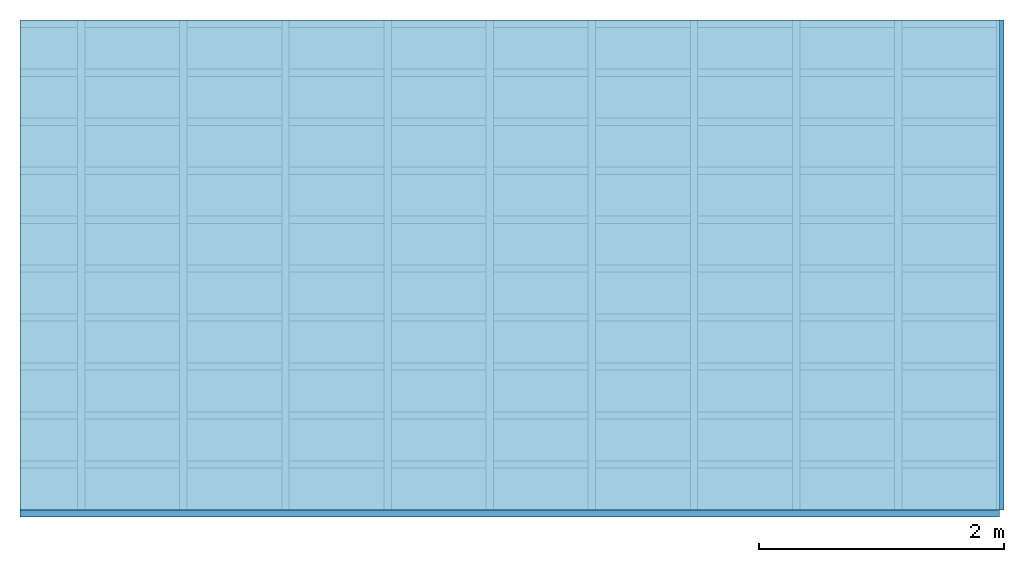
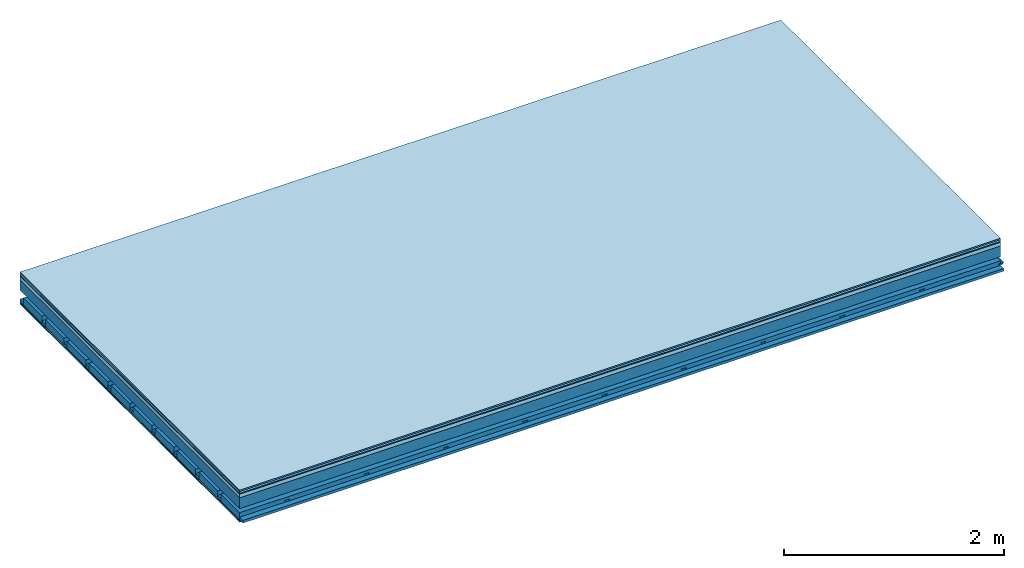
# One storey: 7 plates, 4 members, 1 element without a shape of its own.
"""IFC4 building model written with IfcOpenShell, lengths in metres."""

from ifc_helpers import new_model, si_unit, derived_unit, direction, frame, frame_2d, origin, origin_with_axes, place, context, project, spatial, polyline, rectangle, outline, extrude, material, layer, layer_set, type_object, element, aggregate, save


model = new_model("IFC4")

# Units and contexts
plan_context = context("Plan", 3, precision=1e-05, world=origin(), true_north=direction((0.0, 1.0)))
model_context = context("Model", 3, precision=1e-05, world=origin(), true_north=direction((0.0, 1.0)))
ifc_project = project(units=[si_unit("LENGTHUNIT", "METRE"), derived_unit("SOUNDPRESSUREUNIT", [(si_unit("PRESSUREUNIT", "PASCAL", prefix="MICRO"), 0)]), si_unit("ENERGYUNIT", "JOULE", prefix="MEGA"), si_unit("MASSUNIT", "GRAM", prefix="KILO"), derived_unit("THERMALTRANSMITTANCEUNIT", [(si_unit("POWERUNIT", "WATT"), 1), (si_unit("AREAUNIT", "SQUARE_METRE"), -1), (si_unit("THERMODYNAMICTEMPERATUREUNIT", "KELVIN"), -1)]), derived_unit("AREADENSITYUNIT", [(si_unit("MASSUNIT", "GRAM", prefix="KILO"), 1), (si_unit("AREAUNIT", "SQUARE_METRE"), -1)]), derived_unit("USERDEFINED", [(si_unit("ENERGYUNIT", "JOULE", prefix="MEGA"), 1), (si_unit("AREAUNIT", "SQUARE_METRE"), -1)])], contexts=[plan_context, model_context])

# Site, building, storey
site = spatial("IfcSite", under=ifc_project)
building_placement = place(None, origin())
building = spatial("IfcBuilding", under=site, at=building_placement)
storey_placement = place(building_placement, origin())
storey = spatial("IfcBuildingStorey", under=building, at=storey_placement)

# Slab, members, plates
ifc_material_1 = material(Category="11.013")
ifc_layer_1 = layer(ifc_material_1, 0.015, Name="Flooring")
ifc_material_2 = material(Category="03.007")
ifc_layer_2 = layer(ifc_material_2, 0.02, Name="On-material")
ifc_material_3 = material(Name="Wood fiber generic product", Category="10.009")
ifc_layer_3 = layer(ifc_material_3, 0.01, Name="Impact sound insulation")
ifc_material_4 = material(Name="Concrete panels", Category="02.007")
ifc_layer_4 = layer(ifc_material_4, 0.04, Name="on Supporting structure")
ifc_material_5 = material(Name="no composite action")
ifc_layer_5 = layer(ifc_material_5, 0.0, Name="Bond")
ifc_layer_6 = layer(None, 0.12, Name="Supporting structure")
ifc_layer_7 = layer(ifc_material_5, 0.0, Name="Bond")
ifc_layer_8 = layer(None, 0.095, Name="Coupling")
ifc_layer_9 = layer(None, 0.03, Name="Battens / profiles")
ifc_material_6 = material(Name="Plasterboard type A", Category="03.008")
ifc_layer_10 = layer(ifc_material_6, 0.0125, Name="Ceiling covering 1st layer")
ifc_layer_11 = layer(ifc_material_6, 0.0125, Name="Ceiling covering layer 2")
ifc_material_7 = material(Category="04.001")
ifc_layer_12 = layer(ifc_material_7, 0.003, Name="Surface / treatment")
ifc_layer_set = layer_set([ifc_layer_1, ifc_layer_2, ifc_layer_3, ifc_layer_4, ifc_layer_5, ifc_layer_6, ifc_layer_7, ifc_layer_8, ifc_layer_9, ifc_layer_10, ifc_layer_11, ifc_layer_12])
slab_type = type_object("IfcSlabType", Name="A2132", PredefinedType="NOTDEFINED", material=ifc_layer_set)
slab_placement = place(None, frame((0.0, 0.0, 0.0), z_axis=(0.0, 0.0, -1.0), x_axis=(1.0, 0.0, 0.0)))
slab = element("IfcSlab", 1, at=slab_placement, inside=storey, type_object=slab_type, material=ifc_layer_set, Name="Slab #1")
ifc_material_8 = material(Name="Solid timber panel")
member_1_placement = place(slab_placement, origin())
member_1 = element("IfcMember", 2, at=member_1_placement, material=ifc_material_8, Name="Supporting structure", context=plan_context, shape_type="SweptSolid", body=[
    extrude(rectangle(XDim=1.0, YDim=0.12, at=frame_2d((0.5, 0.06), x_axis=(1.0, 0.0))), frame((0.0, 4.0, 0.085), z_axis=(0.0, -1.0, 0.0), x_axis=(1.0, 0.0, 0.0)), (0.0, 0.0, 1.0), 4.0),
    extrude(rectangle(XDim=1.0, YDim=0.12, at=frame_2d((0.5, 0.06), x_axis=(1.0, 0.0))), frame((1.0, 4.0, 0.085), z_axis=(0.0, -1.0, 0.0), x_axis=(1.0, 0.0, 0.0)), (0.0, 0.0, 1.0), 4.0),
    extrude(rectangle(XDim=1.0, YDim=0.12, at=frame_2d((0.5, 0.06), x_axis=(1.0, 0.0))), frame((2.0, 4.0, 0.085), z_axis=(0.0, -1.0, 0.0), x_axis=(1.0, 0.0, 0.0)), (0.0, 0.0, 1.0), 4.0),
    extrude(rectangle(XDim=1.0, YDim=0.12, at=frame_2d((0.5, 0.06), x_axis=(1.0, 0.0))), frame((3.0, 4.0, 0.085), z_axis=(0.0, -1.0, 0.0), x_axis=(1.0, 0.0, 0.0)), (0.0, 0.0, 1.0), 4.0),
    extrude(rectangle(XDim=1.0, YDim=0.12, at=frame_2d((0.5, 0.06), x_axis=(1.0, 0.0))), frame((4.0, 4.0, 0.085), z_axis=(0.0, -1.0, 0.0), x_axis=(1.0, 0.0, 0.0)), (0.0, 0.0, 1.0), 4.0),
    extrude(rectangle(XDim=1.0, YDim=0.12, at=frame_2d((0.5, 0.06), x_axis=(1.0, 0.0))), frame((5.0, 4.0, 0.085), z_axis=(0.0, -1.0, 0.0), x_axis=(1.0, 0.0, 0.0)), (0.0, 0.0, 1.0), 4.0),
    extrude(rectangle(XDim=1.0, YDim=0.12, at=frame_2d((0.5, 0.06), x_axis=(1.0, 0.0))), frame((6.0, 4.0, 0.085), z_axis=(0.0, -1.0, 0.0), x_axis=(1.0, 0.0, 0.0)), (0.0, 0.0, 1.0), 4.0),
    extrude(rectangle(XDim=1.0, YDim=0.12, at=frame_2d((0.5, 0.06), x_axis=(1.0, 0.0))), frame((7.0, 4.0, 0.085), z_axis=(0.0, -1.0, 0.0), x_axis=(1.0, 0.0, 0.0)), (0.0, 0.0, 1.0), 4.0),
])
ifc_material_9 = material()
member_2_placement = place(slab_placement, origin())
member_2 = element("IfcMember", 3, at=member_2_placement, material=ifc_material_9, Name="Coupling", context=plan_context, shape_type="SweptSolid", body=[
    extrude(outline(polyline([(0.0, 0.0), (0.06, 0.0), (0.04, 0.02), (0.02, 0.02), (0.0, 0.0)])), frame((0.47, 4.0, 0.28), z_axis=(0.0, -1.0, 0.0), x_axis=(1.0, 0.0, 0.0)), (0.0, 0.0, 1.0), 4.0),
    extrude(outline(polyline([(0.0, 0.0), (0.06, 0.0), (0.04, 0.02), (0.02, 0.02), (0.0, 0.0)])), frame((1.304, 4.0, 0.28), z_axis=(0.0, -1.0, 0.0), x_axis=(1.0, 0.0, 0.0)), (0.0, 0.0, 1.0), 4.0),
    extrude(outline(polyline([(0.0, 0.0), (0.06, 0.0), (0.04, 0.02), (0.02, 0.02), (0.0, 0.0)])), frame((2.138, 4.0, 0.28), z_axis=(0.0, -1.0, 0.0), x_axis=(1.0, 0.0, 0.0)), (0.0, 0.0, 1.0), 4.0),
    extrude(outline(polyline([(0.0, 0.0), (0.06, 0.0), (0.04, 0.02), (0.02, 0.02), (0.0, 0.0)])), frame((2.972, 4.0, 0.28), z_axis=(0.0, -1.0, 0.0), x_axis=(1.0, 0.0, 0.0)), (0.0, 0.0, 1.0), 4.0),
    extrude(outline(polyline([(0.0, 0.0), (0.06, 0.0), (0.04, 0.02), (0.02, 0.02), (0.0, 0.0)])), frame((3.806, 4.0, 0.28), z_axis=(0.0, -1.0, 0.0), x_axis=(1.0, 0.0, 0.0)), (0.0, 0.0, 1.0), 4.0),
    extrude(outline(polyline([(0.0, 0.0), (0.06, 0.0), (0.04, 0.02), (0.02, 0.02), (0.0, 0.0)])), frame((4.64, 4.0, 0.28), z_axis=(0.0, -1.0, 0.0), x_axis=(1.0, 0.0, 0.0)), (0.0, 0.0, 1.0), 4.0),
    extrude(outline(polyline([(0.0, 0.0), (0.06, 0.0), (0.04, 0.02), (0.02, 0.02), (0.0, 0.0)])), frame((5.474, 4.0, 0.28), z_axis=(0.0, -1.0, 0.0), x_axis=(1.0, 0.0, 0.0)), (0.0, 0.0, 1.0), 4.0),
    extrude(outline(polyline([(0.0, 0.0), (0.06, 0.0), (0.04, 0.02), (0.02, 0.02), (0.0, 0.0)])), frame((6.308, 4.0, 0.28), z_axis=(0.0, -1.0, 0.0), x_axis=(1.0, 0.0, 0.0)), (0.0, 0.0, 1.0), 4.0),
    extrude(outline(polyline([(0.0, 0.0), (0.06, 0.0), (0.04, 0.02), (0.02, 0.02), (0.0, 0.0)])), frame((7.142, 4.0, 0.28), z_axis=(0.0, -1.0, 0.0), x_axis=(1.0, 0.0, 0.0)), (0.0, 0.0, 1.0), 4.0),
    extrude(outline(polyline([(0.0, 0.0), (0.06, 0.0), (0.04, 0.02), (0.02, 0.02), (0.0, 0.0)])), frame((7.976, 4.0, 0.28), z_axis=(0.0, -1.0, 0.0), x_axis=(1.0, 0.0, 0.0)), (0.0, 0.0, 1.0), 4.0),
])
member_3_placement = place(slab_placement, origin())
member_3 = element("IfcMember", 4, at=member_3_placement, material=ifc_material_9, Name="Battens / profiles", context=plan_context, shape_type="SweptSolid", body=[
    extrude(rectangle(XDim=0.06, YDim=0.03, at=frame_2d((0.03, 0.015), x_axis=(1.0, 0.0))), frame((0.0, 0.0, 0.3), z_axis=(1.0, 0.0, 0.0), x_axis=(0.0, 1.0, 0.0)), (0.0, 0.0, 1.0), 8.0),
    extrude(rectangle(XDim=0.06, YDim=0.03, at=frame_2d((0.03, 0.015), x_axis=(1.0, 0.0))), frame((0.0, 0.4, 0.3), z_axis=(1.0, 0.0, 0.0), x_axis=(0.0, 1.0, 0.0)), (0.0, 0.0, 1.0), 8.0),
    extrude(rectangle(XDim=0.06, YDim=0.03, at=frame_2d((0.03, 0.015), x_axis=(1.0, 0.0))), frame((0.0, 0.8, 0.3), z_axis=(1.0, 0.0, 0.0), x_axis=(0.0, 1.0, 0.0)), (0.0, 0.0, 1.0), 8.0),
    extrude(rectangle(XDim=0.06, YDim=0.03, at=frame_2d((0.03, 0.015), x_axis=(1.0, 0.0))), frame((0.0, 1.2, 0.3), z_axis=(1.0, 0.0, 0.0), x_axis=(0.0, 1.0, 0.0)), (0.0, 0.0, 1.0), 8.0),
    extrude(rectangle(XDim=0.06, YDim=0.03, at=frame_2d((0.03, 0.015), x_axis=(1.0, 0.0))), frame((0.0, 1.6, 0.3), z_axis=(1.0, 0.0, 0.0), x_axis=(0.0, 1.0, 0.0)), (0.0, 0.0, 1.0), 8.0),
    extrude(rectangle(XDim=0.06, YDim=0.03, at=frame_2d((0.03, 0.015), x_axis=(1.0, 0.0))), frame((0.0, 2.0, 0.3), z_axis=(1.0, 0.0, 0.0), x_axis=(0.0, 1.0, 0.0)), (0.0, 0.0, 1.0), 8.0),
    extrude(rectangle(XDim=0.06, YDim=0.03, at=frame_2d((0.03, 0.015), x_axis=(1.0, 0.0))), frame((0.0, 2.4, 0.3), z_axis=(1.0, 0.0, 0.0), x_axis=(0.0, 1.0, 0.0)), (0.0, 0.0, 1.0), 8.0),
    extrude(rectangle(XDim=0.06, YDim=0.03, at=frame_2d((0.03, 0.015), x_axis=(1.0, 0.0))), frame((0.0, 2.8, 0.3), z_axis=(1.0, 0.0, 0.0), x_axis=(0.0, 1.0, 0.0)), (0.0, 0.0, 1.0), 8.0),
    extrude(rectangle(XDim=0.06, YDim=0.03, at=frame_2d((0.03, 0.015), x_axis=(1.0, 0.0))), frame((0.0, 3.2, 0.3), z_axis=(1.0, 0.0, 0.0), x_axis=(0.0, 1.0, 0.0)), (0.0, 0.0, 1.0), 8.0),
    extrude(rectangle(XDim=0.06, YDim=0.03, at=frame_2d((0.03, 0.015), x_axis=(1.0, 0.0))), frame((0.0, 3.6, 0.3), z_axis=(1.0, 0.0, 0.0), x_axis=(0.0, 1.0, 0.0)), (0.0, 0.0, 1.0), 8.0),
    extrude(rectangle(XDim=0.06, YDim=0.03, at=frame_2d((0.03, 0.015), x_axis=(1.0, 0.0))), frame((0.0, 4.0, 0.3), z_axis=(1.0, 0.0, 0.0), x_axis=(0.0, 1.0, 0.0)), (0.0, 0.0, 1.0), 8.0),
])
ifc_material_10 = material()
member_4_placement = place(slab_placement, origin())
member_4 = element("IfcMember", 5, at=member_4_placement, material=ifc_material_10, Name="Cavity", context=plan_context, shape_type="SweptSolid", body=[
    extrude(rectangle(XDim=0.34, YDim=0.08, at=frame_2d((0.17, 0.04), x_axis=(1.0, 0.0))), frame((0.0, 0.06, 0.25), z_axis=(1.0, 0.0, 0.0), x_axis=(0.0, 1.0, 0.0)), (0.0, 0.0, 1.0), 8.0),
    extrude(rectangle(XDim=0.34, YDim=0.08, at=frame_2d((0.17, 0.04), x_axis=(1.0, 0.0))), frame((0.0, 0.46, 0.25), z_axis=(1.0, 0.0, 0.0), x_axis=(0.0, 1.0, 0.0)), (0.0, 0.0, 1.0), 8.0),
    extrude(rectangle(XDim=0.34, YDim=0.08, at=frame_2d((0.17, 0.04), x_axis=(1.0, 0.0))), frame((0.0, 0.86, 0.25), z_axis=(1.0, 0.0, 0.0), x_axis=(0.0, 1.0, 0.0)), (0.0, 0.0, 1.0), 8.0),
    extrude(rectangle(XDim=0.34, YDim=0.08, at=frame_2d((0.17, 0.04), x_axis=(1.0, 0.0))), frame((0.0, 1.26, 0.25), z_axis=(1.0, 0.0, 0.0), x_axis=(0.0, 1.0, 0.0)), (0.0, 0.0, 1.0), 8.0),
    extrude(rectangle(XDim=0.34, YDim=0.08, at=frame_2d((0.17, 0.04), x_axis=(1.0, 0.0))), frame((0.0, 1.66, 0.25), z_axis=(1.0, 0.0, 0.0), x_axis=(0.0, 1.0, 0.0)), (0.0, 0.0, 1.0), 8.0),
    extrude(rectangle(XDim=0.34, YDim=0.08, at=frame_2d((0.17, 0.04), x_axis=(1.0, 0.0))), frame((0.0, 2.06, 0.25), z_axis=(1.0, 0.0, 0.0), x_axis=(0.0, 1.0, 0.0)), (0.0, 0.0, 1.0), 8.0),
    extrude(rectangle(XDim=0.34, YDim=0.08, at=frame_2d((0.17, 0.04), x_axis=(1.0, 0.0))), frame((0.0, 2.46, 0.25), z_axis=(1.0, 0.0, 0.0), x_axis=(0.0, 1.0, 0.0)), (0.0, 0.0, 1.0), 8.0),
    extrude(rectangle(XDim=0.34, YDim=0.08, at=frame_2d((0.17, 0.04), x_axis=(1.0, 0.0))), frame((0.0, 2.86, 0.25), z_axis=(1.0, 0.0, 0.0), x_axis=(0.0, 1.0, 0.0)), (0.0, 0.0, 1.0), 8.0),
    extrude(rectangle(XDim=0.34, YDim=0.08, at=frame_2d((0.17, 0.04), x_axis=(1.0, 0.0))), frame((0.0, 3.26, 0.25), z_axis=(1.0, 0.0, 0.0), x_axis=(0.0, 1.0, 0.0)), (0.0, 0.0, 1.0), 8.0),
    extrude(rectangle(XDim=0.34, YDim=0.08, at=frame_2d((0.17, 0.04), x_axis=(1.0, 0.0))), frame((0.0, 3.66, 0.25), z_axis=(1.0, 0.0, 0.0), x_axis=(0.0, 1.0, 0.0)), (0.0, 0.0, 1.0), 8.0),
])
plate_1_placement = place(slab_placement, origin())
plate_1 = element("IfcPlate", 6, at=plate_1_placement, material=ifc_material_1, Name="Flooring", context=plan_context, shape_type="SweptSolid", body=[
    extrude(rectangle(XDim=8.0, YDim=4.0, at=frame_2d((4.0, 2.0), x_axis=(1.0, 0.0))), origin_with_axes(), (0.0, 0.0, 1.0), 0.015),
])
plate_2_placement = place(slab_placement, origin())
plate_2 = element("IfcPlate", 7, at=plate_2_placement, material=ifc_material_2, Name="On-material", context=plan_context, shape_type="SweptSolid", body=[
    extrude(rectangle(XDim=8.0, YDim=4.0, at=frame_2d((4.0, 2.0), x_axis=(1.0, 0.0))), frame((0.0, 0.0, 0.015), z_axis=(0.0, 0.0, 1.0), x_axis=(1.0, 0.0, 0.0)), (0.0, 0.0, 1.0), 0.02),
])
plate_3_placement = place(slab_placement, origin())
plate_3 = element("IfcPlate", 8, at=plate_3_placement, material=ifc_material_3, Name="Impact sound insulation", context=plan_context, shape_type="SweptSolid", body=[
    extrude(rectangle(XDim=8.0, YDim=4.0, at=frame_2d((4.0, 2.0), x_axis=(1.0, 0.0))), frame((0.0, 0.0, 0.035), z_axis=(0.0, 0.0, 1.0), x_axis=(1.0, 0.0, 0.0)), (0.0, 0.0, 1.0), 0.01),
])
plate_4_placement = place(slab_placement, origin())
plate_4 = element("IfcPlate", 9, at=plate_4_placement, material=ifc_material_4, Name="on Supporting structure", context=plan_context, shape_type="SweptSolid", body=[
    extrude(rectangle(XDim=8.0, YDim=4.0, at=frame_2d((4.0, 2.0), x_axis=(1.0, 0.0))), frame((0.0, 0.0, 0.045), z_axis=(0.0, 0.0, 1.0), x_axis=(1.0, 0.0, 0.0)), (0.0, 0.0, 1.0), 0.04),
])
plate_5_placement = place(slab_placement, origin())
plate_5 = element("IfcPlate", 10, at=plate_5_placement, material=ifc_material_6, Name="Ceiling covering 1st layer", context=plan_context, shape_type="SweptSolid", body=[
    extrude(rectangle(XDim=8.0, YDim=4.0, at=frame_2d((4.0, 2.0), x_axis=(1.0, 0.0))), frame((0.0, 0.0, 0.33), z_axis=(0.0, 0.0, 1.0), x_axis=(1.0, 0.0, 0.0)), (0.0, 0.0, 1.0), 0.0125),
])
plate_6_placement = place(slab_placement, origin())
plate_6 = element("IfcPlate", 11, at=plate_6_placement, material=ifc_material_6, Name="Ceiling covering layer 2", context=plan_context, shape_type="SweptSolid", body=[
    extrude(rectangle(XDim=8.0, YDim=4.0, at=frame_2d((4.0, 2.0), x_axis=(1.0, 0.0))), frame((0.0, 0.0, 0.3425), z_axis=(0.0, 0.0, 1.0), x_axis=(1.0, 0.0, 0.0)), (0.0, 0.0, 1.0), 0.0125),
])
plate_7_placement = place(slab_placement, origin())
plate_7 = element("IfcPlate", 12, at=plate_7_placement, material=ifc_material_7, Name="Surface / treatment", context=plan_context, shape_type="SweptSolid", body=[
    extrude(rectangle(XDim=8.0, YDim=4.0, at=frame_2d((4.0, 2.0), x_axis=(1.0, 0.0))), frame((0.0, 0.0, 0.355), z_axis=(0.0, 0.0, 1.0), x_axis=(1.0, 0.0, 0.0)), (0.0, 0.0, 1.0), 0.003),
])
aggregate(slab, [plate_1, plate_2, plate_3, plate_4, member_1, member_2, member_3, member_4, plate_5, plate_6, plate_7])

save(model, "model.ifc")
